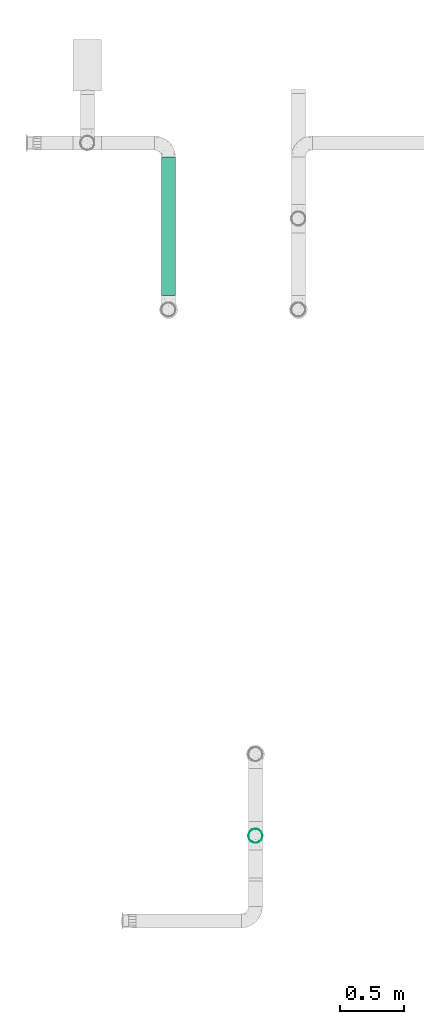
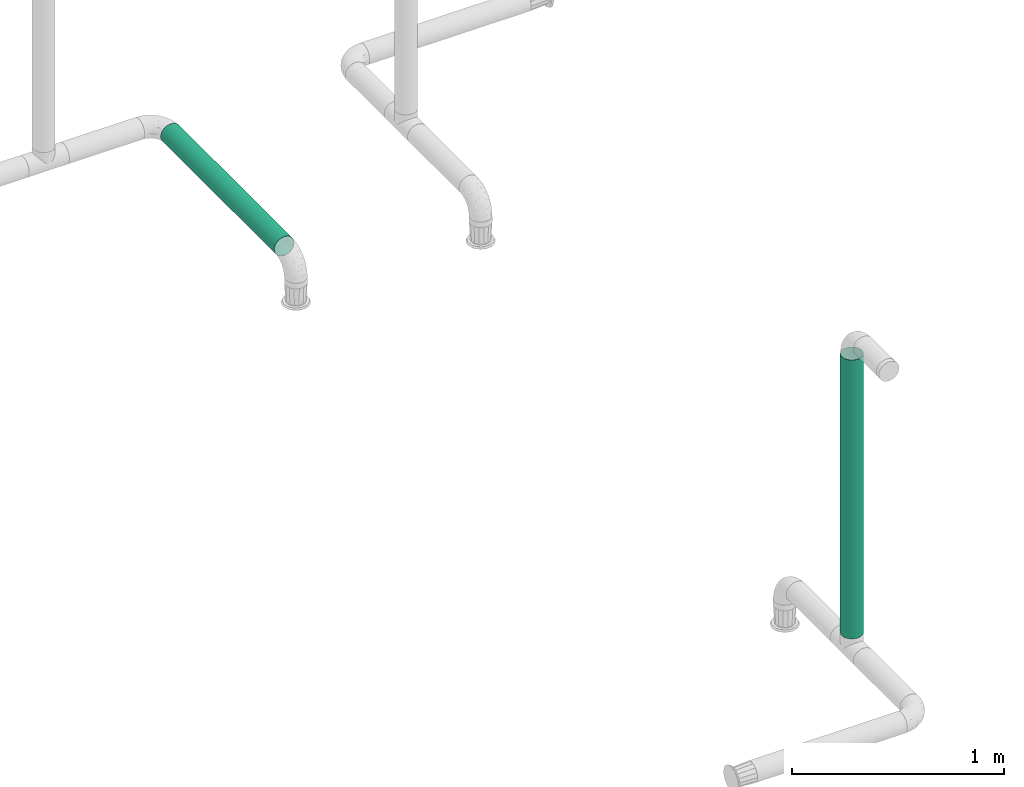
# One storey, part 5 of 103: 2 flow segments.
"""IFC2X3 building model written with IfcOpenShell, lengths in millimetres."""

from ifc_helpers import new_model, entity, si_unit, converted_unit, derived_unit, direction, frame, origin_with_axes, origin_2d_with_axis, place, context, subcontext, project, spatial, hollow_circle, extrude, source, transform, mapped, material, layer, layer_set, layer_usage, type_object, element, save


model = new_model("IFC2X3")

# Units and contexts
model_context = context("Model", 3, precision=1e-05, world=origin_with_axes(), true_north=direction((0.0, 1.0)))
body_context = subcontext(model_context, "Body", "Model", "MODEL_VIEW")
ifc_project = project(units=[si_unit("AREAUNIT", "SQUARE_METRE"), si_unit("VOLUMEUNIT", "CUBIC_METRE", prefix="DECI"), si_unit("TIMEUNIT", "SECOND"), si_unit("THERMODYNAMICTEMPERATUREUNIT", "DEGREE_CELSIUS"), si_unit("PRESSUREUNIT", "PASCAL"), si_unit("MASSUNIT", "GRAM", prefix="KILO"), si_unit("LENGTHUNIT", "METRE", prefix="MILLI"), si_unit("POWERUNIT", "WATT"), si_unit("ELECTRICCURRENTUNIT", "AMPERE"), si_unit("ELECTRICVOLTAGEUNIT", "VOLT"), derived_unit("VOLUMETRICFLOWRATEUNIT", [(si_unit("VOLUMEUNIT", "CUBIC_METRE", prefix="DECI"), 1), (si_unit("TIMEUNIT", "SECOND"), -1)]), derived_unit("LINEARVELOCITYUNIT", [(si_unit("LENGTHUNIT", "METRE"), 1), (si_unit("TIMEUNIT", "SECOND"), -1)]), derived_unit("MASSDENSITYUNIT", [(si_unit("MASSUNIT", "GRAM", prefix="KILO"), 1), (si_unit("VOLUMEUNIT", "CUBIC_METRE"), -1)]), converted_unit("PLANEANGLEUNIT", "DEGREE", entity("IfcRatioMeasure", 0.01745), si_unit("PLANEANGLEUNIT", "RADIAN"), dimensions=[0, 0, 0, 0, 0, 0, 0])], contexts=[model_context])

# Site, building, storey
site_placement = place(None, origin_with_axes())
site = spatial("IfcSite", under=ifc_project, at=site_placement, CompositionType="ELEMENT")
building_placement = place(site_placement, origin_with_axes())
building = spatial("IfcBuilding", under=site, at=building_placement, Name="mc-building", CompositionType="ELEMENT")
storey_placement = place(building_placement, frame((0.0, 0.0, 5900.0), z_axis=(0.0, 0.0, 1.0), x_axis=(1.0, 0.0, 0.0)))
storey = spatial("IfcBuildingStorey", under=building, at=storey_placement, Name="3. Korrus", CompositionType="ELEMENT", Elevation=5900.0)

# Flow segments
ifc_material = material(Name="FZ1")
ifc_layer = layer(ifc_material, 0.0)
ifc_layer_set = layer_set([ifc_layer], Name="FZ1")
ifc_layer_usage = layer_usage(ifc_layer_set, "AXIS1", "POSITIVE", 0.0)
duct_segment_type_1 = type_object("IfcDuctSegmentType", PredefinedType="RIGIDSEGMENT")
shared_shape_1 = source(origin_with_axes(), body_context, "Body", "SweptSolid", [
    extrude(hollow_circle(Radius=55.0, WallThickness=2.0, at=origin_2d_with_axis()), frame((0.0, 0.0, 0.0), z_axis=(1.0, 0.0, 0.0), x_axis=(0.0, 1.0, 0.0)), (0.0, 0.0, 1.0), 1074.1),
])
flow_segment_1_placement = place(storey_placement, frame((33106.64841, 9367.62755, 2345.0), z_axis=(0.0, 0.0, 1.0), x_axis=(0.0, -1.0, 0.0)))
element("IfcFlowSegment", 1, at=flow_segment_1_placement, inside=storey, type_object=duct_segment_type_1, material=ifc_layer_usage, context=body_context, shape_type="MappedRepresentation", body=[
    mapped(shared_shape_1, transform((0.0, 0.0, 0.0), scale=1.0)),
])
duct_segment_type_2 = type_object("IfcDuctSegmentType", Name="Safe", PredefinedType="RIGIDSEGMENT")
shared_shape_2 = source(origin_with_axes(), body_context, "Body", "SweptSolid", [
    extrude(hollow_circle(Radius=55.0, WallThickness=2.0, at=origin_2d_with_axis()), frame((0.0, 0.0, 0.0), z_axis=(1.0, 0.0, 0.0), x_axis=(0.0, 1.0, 0.0)), (0.0, 0.0, 1.0), 1609.0),
])
flow_segment_2_placement = place(storey_placement, frame((33781.67179, 4097.31763, 2425.0), z_axis=(0.0, -1.0, 0.0), x_axis=(0.0, 0.0, 1.0)))
element("IfcFlowSegment", 2, at=flow_segment_2_placement, inside=storey, type_object=duct_segment_type_2, material=ifc_layer_usage, Name="Safe", context=body_context, shape_type="MappedRepresentation", body=[
    mapped(shared_shape_2, transform((0.0, 0.0, 0.0), scale=1.0)),
])

save(model, "model.ifc")
